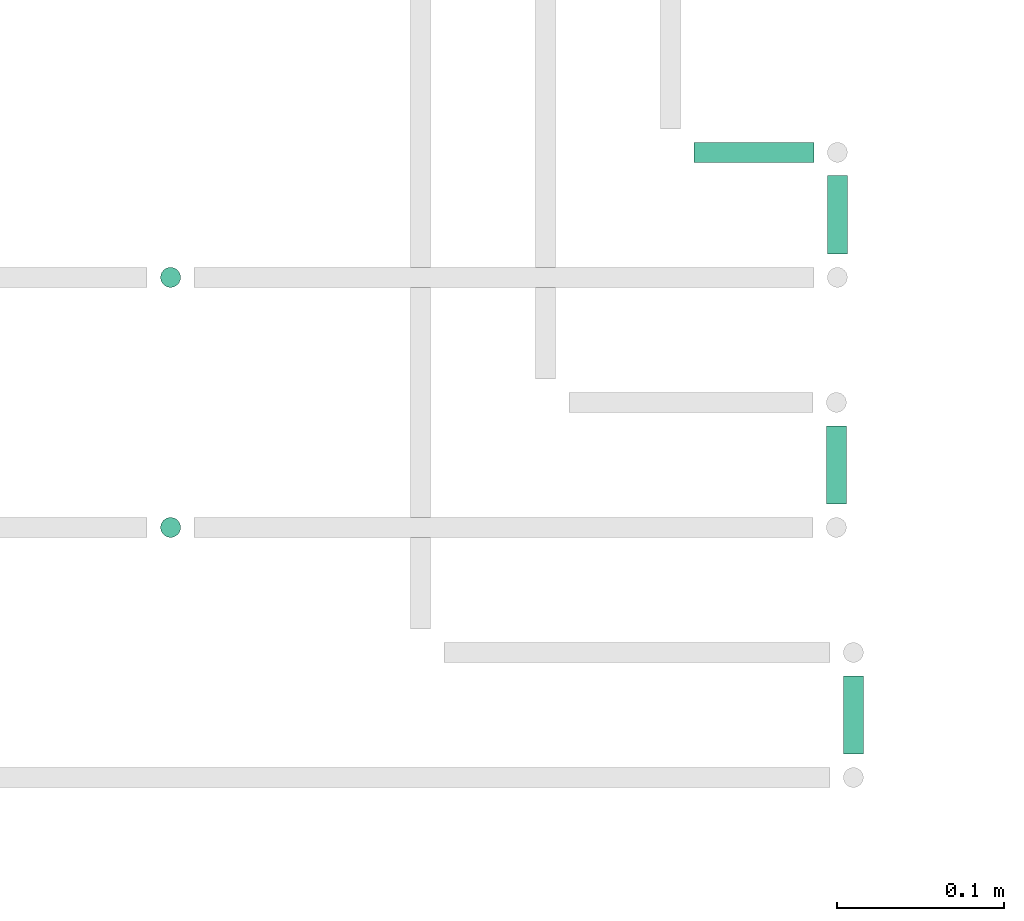
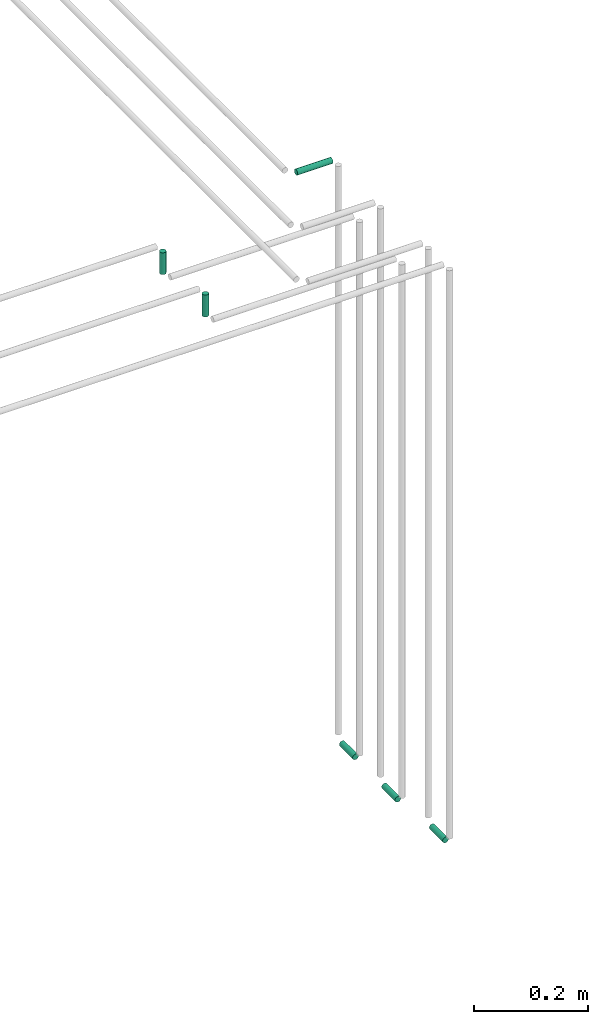
# One storey, part 267 of 331: 6 flow segments.
"""IFC2X3 building model written with IfcOpenShell, lengths in millimetres."""

from ifc_helpers import new_model, entity, si_unit, converted_unit, derived_unit, direction, frame, frame_2d, origin, origin_2d_with_axis, place, context, subcontext, project, spatial, circle, extrude, type_object, element, save


model = new_model("IFC2X3")

# Units and contexts
model_context = context("Model", 3, precision=0.01, world=origin(), true_north=direction((6.12303176911189e-17, 1.0)))
body_context = subcontext(model_context, "Body", "Model", "MODEL_VIEW")
ifc_project = project(units=[si_unit("LENGTHUNIT", "METRE", prefix="MILLI"), si_unit("AREAUNIT", "SQUARE_METRE"), si_unit("VOLUMEUNIT", "CUBIC_METRE"), converted_unit("PLANEANGLEUNIT", "DEGREE", entity("IfcRatioMeasure", 0.0174532925199433), si_unit("PLANEANGLEUNIT", "RADIAN"), dimensions=[0, 0, 0, 0, 0, 0, 0]), si_unit("MASSUNIT", "GRAM", prefix="KILO"), derived_unit("MASSDENSITYUNIT", [(si_unit("MASSUNIT", "GRAM", prefix="KILO"), 1), (si_unit("LENGTHUNIT", "METRE"), -3)]), derived_unit("MOMENTOFINERTIAUNIT", [(si_unit("LENGTHUNIT", "METRE"), 4)]), si_unit("TIMEUNIT", "SECOND"), si_unit("FREQUENCYUNIT", "HERTZ"), si_unit("THERMODYNAMICTEMPERATUREUNIT", "DEGREE_CELSIUS"), derived_unit("THERMALTRANSMITTANCEUNIT", [(si_unit("MASSUNIT", "GRAM", prefix="KILO"), 1), (si_unit("THERMODYNAMICTEMPERATUREUNIT", "KELVIN"), -1), (si_unit("TIMEUNIT", "SECOND"), -3)]), derived_unit("VOLUMETRICFLOWRATEUNIT", [(si_unit("LENGTHUNIT", "METRE"), 3), (si_unit("TIMEUNIT", "SECOND"), -1)]), derived_unit("MASSFLOWRATEUNIT", [(si_unit("MASSUNIT", "GRAM", prefix="KILO"), 1), (si_unit("TIMEUNIT", "SECOND"), -1)]), derived_unit("ROTATIONALFREQUENCYUNIT", [(si_unit("TIMEUNIT", "SECOND"), -1)]), si_unit("ELECTRICCURRENTUNIT", "AMPERE"), si_unit("ELECTRICVOLTAGEUNIT", "VOLT"), si_unit("POWERUNIT", "WATT"), si_unit("FORCEUNIT", "NEWTON", prefix="KILO"), si_unit("ILLUMINANCEUNIT", "LUX"), si_unit("LUMINOUSFLUXUNIT", "LUMEN"), si_unit("LUMINOUSINTENSITYUNIT", "CANDELA"), derived_unit("USERDEFINED", [(si_unit("MASSUNIT", "GRAM", prefix="KILO"), -1), (si_unit("LENGTHUNIT", "METRE"), -2), (si_unit("TIMEUNIT", "SECOND"), 3), (si_unit("LUMINOUSFLUXUNIT", "LUMEN"), 1)]), derived_unit("LINEARVELOCITYUNIT", [(si_unit("LENGTHUNIT", "METRE"), 1), (si_unit("TIMEUNIT", "SECOND"), -1)]), si_unit("PRESSUREUNIT", "PASCAL"), derived_unit("USERDEFINED", [(si_unit("LENGTHUNIT", "METRE"), -2), (si_unit("MASSUNIT", "GRAM", prefix="KILO"), 1), (si_unit("TIMEUNIT", "SECOND"), -2)]), derived_unit("LINEARFORCEUNIT", [(si_unit("MASSUNIT", "GRAM", prefix="KILO"), 1), (si_unit("LENGTHUNIT", "METRE"), 1), (si_unit("TIMEUNIT", "SECOND"), -2), (si_unit("LENGTHUNIT", "METRE"), -1)]), derived_unit("PLANARFORCEUNIT", [(si_unit("MASSUNIT", "GRAM", prefix="KILO"), 1), (si_unit("LENGTHUNIT", "METRE"), 1), (si_unit("TIMEUNIT", "SECOND"), -2), (si_unit("LENGTHUNIT", "METRE"), -2)])], contexts=[model_context])

# Site, building, storey
site_placement = place(None, frame((0.0, -0.00077364408347762, 0.0)))
site = spatial("IfcSite", under=ifc_project, at=site_placement, CompositionType="ELEMENT")
building_placement = place(site_placement, origin())
building = spatial("IfcBuilding", under=site, at=building_placement, CompositionType="ELEMENT")
storey_placement = place(building_placement, origin())
storey = spatial("IfcBuildingStorey", under=building, at=storey_placement, CompositionType="ELEMENT", Elevation=0.0)

# Flow segments
pipe_segment_type = type_object("IfcPipeSegmentType", PredefinedType="NOTDEFINED")
flow_segment_1_placement = place(building_placement, frame((34758.9328642121, 13354.8700236546, 6742.40472776408)))
element("IfcFlowSegment", 1, at=flow_segment_1_placement, inside=storey, type_object=pipe_segment_type, context=body_context, shape_type="SweptSolid", body=[
    extrude(circle(Radius=6.0, at=origin_2d_with_axis()), frame((0.0, 7.5952722359167, 7.59527223591562), z_axis=(1.0, 0.0, 0.0), x_axis=(0.0, -1.0, 0.0)), (0.0, 0.0, 1.0), 72.0000000000096),
])
for number, where in (
    (2, (34846.9512077447, 13001.4652958905, 5492.40472776408)),
    (3, (34836.7603220303, 13151.4652958905, 5492.40472776408)),
):
    element("IfcFlowSegment", number, at=place(building_placement, frame(where)), inside=storey, type_object=pipe_segment_type, context=body_context, shape_type="SweptSolid", body=[
        extrude(circle(Radius=6.0, at=frame_2d((0.0, -1.08286712929839e-12), x_axis=(1.0, 0.0))), frame((7.59527223591454, 0.0, 7.5952722359167), z_axis=(0.0, 1.0, 0.0), x_axis=(-1.0, 0.0, 0.0)), (0.0, 0.0, 1.0), 47.000000000011),
    ])
flow_segment_2_placement = place(building_placement, frame((34837.3375919762, 13301.4652958905, 5492.40472776408)))
element("IfcFlowSegment", 4, at=flow_segment_2_placement, inside=storey, type_object=pipe_segment_type, context=body_context, shape_type="SweptSolid", body=[
    extrude(circle(Radius=6.0, at=frame_2d((0.0, -1.08286712929839e-12), x_axis=(1.0, 0.0))), frame((7.59527223591454, 0.0, 7.5952722359167), z_axis=(0.0, 1.0, 0.0), x_axis=(-1.0, 0.0, 0.0)), (0.0, 0.0, 1.0), 47.0000000000175),
])
flow_segment_3_placement = place(building_placement, frame((34437.3375919762, 13279.8700236546, 6689.0)))
element("IfcFlowSegment", 5, at=flow_segment_3_placement, inside=storey, type_object=pipe_segment_type, context=body_context, shape_type="SweptSolid", body=[
    extrude(circle(Radius=6.0, at=origin_2d_with_axis()), frame((7.59527223591454, 7.5952722359167, 0.0), z_axis=(0.0, 0.0, 1.0), x_axis=(-1.0, 0.0, 0.0)), (0.0, 0.0, 1.0), 47.0000000000121),
])
flow_segment_4_placement = place(building_placement, frame((34437.3375919762, 13129.8700236546, 6689.0)))
element("IfcFlowSegment", 6, at=flow_segment_4_placement, inside=storey, type_object=pipe_segment_type, context=body_context, shape_type="SweptSolid", body=[
    extrude(circle(Radius=6.0, at=frame_2d((0.0, -2.16573425859679e-12), x_axis=(1.0, 0.0))), frame((7.59527223591454, 7.59527223591454, 0.0), z_axis=(0.0, 0.0, 1.0), x_axis=(-1.0, 0.0, 0.0)), (0.0, 0.0, 1.0), 47.0000000000153),
])

save(model, "model.ifc")
